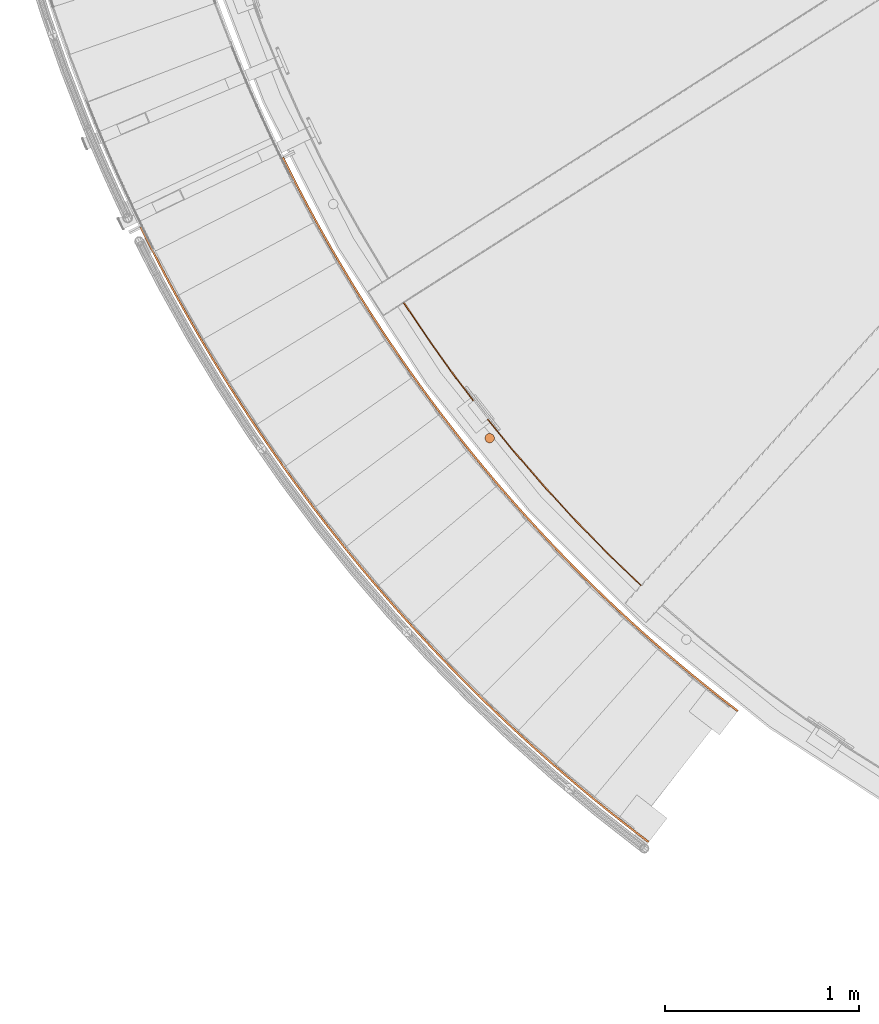
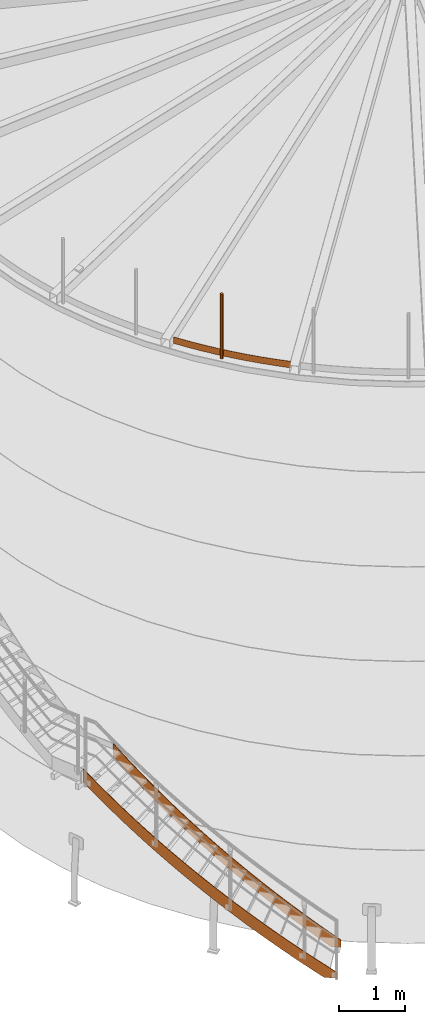
# One storey, part 4 of 126: 4 proxies.
"""IFC2X3 building model written with IfcOpenShell, lengths in millimetres."""

from ifc_helpers import new_model, si_unit, origin, origin_with_axes, place, context, project, spatial, faceted_brep, material, element, save


model = new_model("IFC2X3")

# Units and contexts
context_of_model_1 = context(None, 3, precision=0.1, world=origin())
context_of_model_2 = context(None, 3, precision=0.1, world=origin())
ifc_project = project(units=[si_unit("LENGTHUNIT", "METRE", prefix="MILLI"), si_unit("AREAUNIT", "SQUARE_METRE", prefix="CENTI"), si_unit("VOLUMEUNIT", "CUBIC_METRE", prefix="CENTI"), si_unit("MASSUNIT", "GRAM", prefix="KILO")], contexts=[context_of_model_1, context_of_model_2])

# Site, building, storey
site_placement = place(None, origin_with_axes())
site = spatial("IfcSite", under=ifc_project, at=site_placement, CompositionType="ELEMENT")
building_placement = place(site_placement, origin_with_axes())
building = spatial("IfcBuilding", under=site, at=building_placement, CompositionType="ELEMENT")
storey_placement = place(building_placement, origin_with_axes())
storey = spatial("IfcBuildingStorey", under=building, at=storey_placement, CompositionType="ELEMENT")

# Proxies
ifc_material_1 = material(Name="S235JRG2")
proxy_1_placement = place(storey_placement, origin_with_axes())
element("IfcBuildingElementProxy", 1, at=proxy_1_placement, inside=storey, material=ifc_material_1, context=context_of_model_2, shape_type="Brep", body=[
    faceted_brep([(2625.5117, 1016.7337, -0.15), (2625.5117, 1016.7337, 169.2948), (2697.6981, 961.7717, 108.7628), (2697.6981, 961.7717, -0.15), (2619.4117, 1008.8095, 169.3301), (2691.5898, 953.8538, 108.8737), (2619.4117, 1008.8095, -0.15), (2691.5898, 953.8538, -0.15), (2551.8092, 1074.0932, -0.15), (2551.8092, 1074.0932, 231.6041), (2545.6256, 1066.234, 231.6394), (2545.6256, 1066.234, -0.15), (2472.4517, 1124.4367, 53.6023), (2478.7181, 1132.2299, 53.4904), (2541.6434, 1082.179, -0.15), (2535.5735, 1074.2295, -0.15), (2478.7181, 1132.2299, 293.9133), (2472.4517, 1124.4367, 293.9486), (2399.8983, 1183.411, 115.9132), (2406.2469, 1191.1374, 115.798), (2406.2469, 1191.1374, 356.2226), (2399.8983, 1183.411, 356.2579), (2327.9735, 1243.1503, 178.2234), (2334.4035, 1250.8091, 178.1064), (2334.4035, 1250.8091, 418.5318), (2327.9735, 1243.1503, 418.5671), (2256.6853, 1303.648, 240.5331), (2263.1961, 1311.2382, 240.4151), (2263.1961, 1311.2382, 480.8411), (2256.6853, 1303.648, 480.8764), (2186.0418, 1364.8971, 302.8426), (2192.6326, 1372.418, 302.7241), (2192.6326, 1372.418, 543.1503), (2186.0418, 1364.8971, 543.1856), (2116.0508, 1426.891, 365.152), (2122.7209, 1434.3416, 365.0332), (2122.7209, 1434.3416, 605.4596), (2116.0508, 1426.891, 605.4949), (2046.7203, 1489.6225, 427.4613), (2053.4689, 1497.0021, 427.3424), (2053.4689, 1497.0021, 667.7688), (2046.7203, 1489.6225, 667.8041), (1978.058, 1553.0847, 489.7706), (1984.8844, 1560.3925, 489.6516), (1984.8844, 1560.3925, 730.0781), (1978.058, 1553.0847, 730.1134), (1910.0715, 1617.2705, 552.0799), (1916.9749, 1624.5056, 551.9608), (1916.9749, 1624.5056, 792.3873), (1910.0715, 1617.2705, 792.4226), (1842.7686, 1682.1727, 614.3892), (1849.7483, 1689.3342, 614.27), (1849.7483, 1689.3342, 854.6966), (1842.7686, 1682.1727, 854.7319), (1776.1568, 1747.7839, 676.6984), (1783.2119, 1754.8711, 676.5793), (1783.2119, 1754.8711, 917.0058), (1776.1568, 1747.7839, 917.0411), (1710.2435, 1814.0969, 739.0077), (1717.3733, 1821.109, 738.8885), (1717.3733, 1821.109, 979.315), (1710.2435, 1814.0969, 979.3504), (1645.0362, 1881.1041, 801.3169), (1652.2398, 1888.0403, 801.1978), (1652.2398, 1888.0403, 1041.6243), (1645.0362, 1881.1041, 1041.6596), (1580.5421, 1948.7981, 863.6262), (1587.8187, 1955.6577, 863.507), (1587.8187, 1955.6577, 1103.9335), (1580.5421, 1948.7981, 1103.9688), (1516.7685, 2017.1713, 925.9354), (1524.1174, 2023.9534, 925.8163), (1524.1174, 2023.9534, 1166.2428), (1516.7685, 2017.1713, 1166.2781), (1453.7225, 2086.2161, 988.2447), (1461.1428, 2092.92, 988.1255), (1461.1428, 2092.92, 1228.552), (1453.7225, 2086.2161, 1228.5873), (1391.4112, 2155.9245, 1050.5539), (1398.9021, 2162.5495, 1050.4347), (1398.9021, 2162.5495, 1290.8613), (1391.4112, 2155.9245, 1290.8966), (1329.8416, 2226.289, 1112.8631), (1337.4022, 2232.8342, 1112.744), (1337.4022, 2232.8342, 1353.1705), (1329.8416, 2226.289, 1353.2058), (1269.0206, 2297.3015, 1175.1724), (1276.6501, 2303.7663, 1175.0532), (1276.6501, 2303.7663, 1415.4798), (1269.0206, 2297.3015, 1415.5151), (1208.9551, 2368.9541, 1237.4816), (1216.6526, 2375.3377, 1237.3625), (1216.6526, 2375.3377, 1477.789), (1208.9551, 2368.9541, 1477.8243), (1149.6517, 2441.2388, 1299.7909), (1157.4163, 2447.5405, 1299.6717), (1157.4163, 2447.5405, 1540.0983), (1149.6517, 2441.2388, 1540.1336), (1091.117, 2514.1474, 1362.1001), (1098.948, 2520.3666, 1361.981), (1098.948, 2520.3666, 1602.4075), (1091.117, 2514.1474, 1602.4428), (1033.3578, 2587.6718, 1424.4094), (1041.2542, 2593.8077, 1424.2902), (1041.2542, 2593.8077, 1664.7168), (1033.3578, 2587.6718, 1664.7521), (976.3804, 2661.8037, 1486.7186), (984.3413, 2667.8557, 1486.5995), (984.3413, 2667.8557, 1727.026), (976.3804, 2661.8037, 1727.0613), (920.1912, 2736.5349, 1549.0279), (928.2158, 2742.5022, 1548.9087), (928.2158, 2742.5022, 1789.3353), (920.1912, 2736.5349, 1789.3706), (864.7966, 2811.8569, 1611.3371), (872.8839, 2817.7389, 1611.218), (872.8839, 2817.7389, 1851.6445), (864.7966, 2811.8569, 1851.6798), (810.2027, 2887.7613, 1673.6464), (818.3519, 2893.5573, 1673.5272), (818.3519, 2893.5573, 1913.9538), (810.2027, 2887.7613, 1913.9891), (756.4157, 2964.2396, 1735.9556), (764.6258, 2969.949, 1735.8365), (764.6258, 2969.949, 1976.263), (756.4157, 2964.2396, 1976.2983), (703.4416, 3041.2831, 1798.2649), (711.7117, 3046.9053, 1798.1457), (711.7117, 3046.9053, 2038.5723), (703.4416, 3041.2831, 2038.6076), (651.2863, 3118.8834, 1860.5741), (659.6155, 3124.4176, 1860.455), (659.6155, 3124.4176, 2100.8815), (651.2863, 3118.8834, 2100.9168), (599.9558, 3197.0316, 1922.8834), (608.3431, 3202.4773, 1922.7642), (608.3431, 3202.4773, 2163.1908), (599.9558, 3197.0316, 2163.2261), (549.4556, 3275.719, 1985.1926), (557.9001, 3281.0756, 1985.0735), (557.9001, 3281.0756, 2225.5), (549.4556, 3275.719, 2225.5353), (499.7916, 3354.9367, 2047.5019), (508.2924, 3360.2036, 2047.3827), (508.2924, 3360.2036, 2287.8092), (499.7916, 3354.9367, 2287.8446), (450.9693, 3434.676, 2109.8111), (459.5254, 3439.8526, 2109.692), (459.5254, 3439.8526, 2350.1185), (450.9693, 3434.676, 2350.1538), (402.9941, 3514.9278, 2172.1204), (411.6045, 3520.0135, 2172.0012), (411.6045, 3520.0135, 2412.4277), (402.9941, 3514.9278, 2412.463), (355.8715, 3595.6832, 2234.4296), (364.5353, 3600.6774, 2234.3105), (364.5353, 3600.6774, 2474.737), (355.8715, 3595.6832, 2474.7723), (309.6067, 3676.933, 2296.7389), (318.3229, 3681.8352, 2296.6197), (318.3229, 3681.8352, 2537.0462), (309.6067, 3676.933, 2537.0815), (264.2049, 3758.6682, 2359.0481), (272.9725, 3763.4778, 2358.9289), (272.9725, 3763.4778, 2599.3555), (264.2049, 3758.6682, 2599.3908), (219.6713, 3840.8797, 2421.3573), (228.4893, 3845.5961, 2421.2382), (228.4893, 3845.5961, 2661.6647), (219.6713, 3840.8797, 2661.7), (176.0107, 3923.5581, 2483.6666), (184.8781, 3928.1809, 2483.5474), (184.8781, 3928.1809, 2723.974), (176.0107, 3923.5581, 2724.0093), (133.2281, 4006.6942, 2545.9758), (142.144, 4011.2229, 2545.8567), (142.144, 4011.2229, 2786.2832), (133.2281, 4006.6942, 2786.3185), (91.3283, 4090.2788, 2608.2851), (100.2917, 4094.7128, 2608.1659), (100.2917, 4094.7128, 2848.5925), (91.3283, 4090.2788, 2848.6278), (76.422, 4120.8179, 2630.932), (85.3295, 4125.3664, 2630.9235), (85.3295, 4125.3664, 2871.35), (76.422, 4120.8179, 2871.2747)], [[[0, 1, 2, 3]], [[1, 4, 5, 2]], [[4, 6, 7, 5]], [[1, 0, 8, 9]], [[1, 9, 10, 4]], [[4, 10, 11, 6]], [[12, 13, 14, 15]], [[13, 16, 9, 8, 14]], [[9, 16, 17, 10]], [[17, 12, 15, 11, 10]], [[12, 18, 19, 13]], [[13, 19, 20, 16]], [[16, 20, 21, 17]], [[17, 21, 18, 12]], [[18, 22, 23, 19]], [[19, 23, 24, 20]], [[20, 24, 25, 21]], [[21, 25, 22, 18]], [[22, 26, 27, 23]], [[23, 27, 28, 24]], [[24, 28, 29, 25]], [[25, 29, 26, 22]], [[26, 30, 31, 27]], [[27, 31, 32, 28]], [[28, 32, 33, 29]], [[29, 33, 30, 26]], [[30, 34, 35, 31]], [[31, 35, 36, 32]], [[32, 36, 37, 33]], [[33, 37, 34, 30]], [[34, 38, 39, 35]], [[35, 39, 40, 36]], [[36, 40, 41, 37]], [[37, 41, 38, 34]], [[38, 42, 43, 39]], [[39, 43, 44, 40]], [[40, 44, 45, 41]], [[41, 45, 42, 38]], [[42, 46, 47, 43]], [[43, 47, 48, 44]], [[44, 48, 49, 45]], [[45, 49, 46, 42]], [[46, 50, 51, 47]], [[47, 51, 52, 48]], [[48, 52, 53, 49]], [[49, 53, 50, 46]], [[50, 54, 55, 51]], [[51, 55, 56, 52]], [[52, 56, 57, 53]], [[53, 57, 54, 50]], [[54, 58, 59, 55]], [[55, 59, 60, 56]], [[56, 60, 61, 57]], [[57, 61, 58, 54]], [[58, 62, 63, 59]], [[59, 63, 64, 60]], [[60, 64, 65, 61]], [[61, 65, 62, 58]], [[62, 66, 67, 63]], [[63, 67, 68, 64]], [[64, 68, 69, 65]], [[65, 69, 66, 62]], [[66, 70, 71, 67]], [[67, 71, 72, 68]], [[68, 72, 73, 69]], [[69, 73, 70, 66]], [[70, 74, 75, 71]], [[71, 75, 76, 72]], [[72, 76, 77, 73]], [[73, 77, 74, 70]], [[74, 78, 79, 75]], [[75, 79, 80, 76]], [[76, 80, 81, 77]], [[77, 81, 78, 74]], [[78, 82, 83, 79]], [[79, 83, 84, 80]], [[80, 84, 85, 81]], [[81, 85, 82, 78]], [[82, 86, 87, 83]], [[83, 87, 88, 84]], [[84, 88, 89, 85]], [[85, 89, 86, 82]], [[86, 90, 91, 87]], [[87, 91, 92, 88]], [[88, 92, 93, 89]], [[89, 93, 90, 86]], [[90, 94, 95, 91]], [[91, 95, 96, 92]], [[92, 96, 97, 93]], [[93, 97, 94, 90]], [[94, 98, 99, 95]], [[95, 99, 100, 96]], [[96, 100, 101, 97]], [[97, 101, 98, 94]], [[98, 102, 103, 99]], [[99, 103, 104, 100]], [[100, 104, 105, 101]], [[101, 105, 102, 98]], [[102, 106, 107, 103]], [[103, 107, 108, 104]], [[104, 108, 109, 105]], [[105, 109, 106, 102]], [[106, 110, 111, 107]], [[107, 111, 112, 108]], [[108, 112, 113, 109]], [[109, 113, 110, 106]], [[110, 114, 115, 111]], [[111, 115, 116, 112]], [[112, 116, 117, 113]], [[113, 117, 114, 110]], [[114, 118, 119, 115]], [[115, 119, 120, 116]], [[116, 120, 121, 117]], [[117, 121, 118, 114]], [[118, 122, 123, 119]], [[119, 123, 124, 120]], [[120, 124, 125, 121]], [[121, 125, 122, 118]], [[122, 126, 127, 123]], [[123, 127, 128, 124]], [[124, 128, 129, 125]], [[125, 129, 126, 122]], [[126, 130, 131, 127]], [[127, 131, 132, 128]], [[128, 132, 133, 129]], [[129, 133, 130, 126]], [[130, 134, 135, 131]], [[131, 135, 136, 132]], [[132, 136, 137, 133]], [[133, 137, 134, 130]], [[134, 138, 139, 135]], [[135, 139, 140, 136]], [[136, 140, 141, 137]], [[137, 141, 138, 134]], [[138, 142, 143, 139]], [[139, 143, 144, 140]], [[140, 144, 145, 141]], [[141, 145, 142, 138]], [[142, 146, 147, 143]], [[143, 147, 148, 144]], [[144, 148, 149, 145]], [[145, 149, 146, 142]], [[146, 150, 151, 147]], [[147, 151, 152, 148]], [[148, 152, 153, 149]], [[149, 153, 150, 146]], [[150, 154, 155, 151]], [[151, 155, 156, 152]], [[152, 156, 157, 153]], [[153, 157, 154, 150]], [[154, 158, 159, 155]], [[155, 159, 160, 156]], [[156, 160, 161, 157]], [[157, 161, 158, 154]], [[158, 162, 163, 159]], [[159, 163, 164, 160]], [[160, 164, 165, 161]], [[161, 165, 162, 158]], [[162, 166, 167, 163]], [[163, 167, 168, 164]], [[164, 168, 169, 165]], [[165, 169, 166, 162]], [[166, 170, 171, 167]], [[167, 171, 172, 168]], [[168, 172, 173, 169]], [[169, 173, 170, 166]], [[170, 174, 175, 171]], [[171, 175, 176, 172]], [[172, 176, 177, 173]], [[173, 177, 174, 170]], [[174, 178, 179, 175]], [[175, 179, 180, 176]], [[176, 180, 181, 177]], [[177, 181, 178, 174]], [[178, 182, 183, 179]], [[179, 183, 184, 180]], [[180, 184, 185, 181]], [[178, 181, 185, 182]], [[182, 185, 184, 183]], [[15, 14, 8, 0, 3, 7, 6, 11]], [[2, 5, 7, 3]]]),
])
proxy_2_placement = place(storey_placement, origin_with_axes())
element("IfcBuildingElementProxy", 2, at=proxy_2_placement, inside=storey, material=ifc_material_1, context=context_of_model_2, shape_type="Brep", body=[
    faceted_brep([(3122.0424, 1661.7556, -0.15), (3122.0424, 1661.7556, 169.293), (3156.2567, 1635.7052, 137.6852), (3156.2567, 1635.7052, -0.15), (3115.9424, 1653.8314, 169.3319), (3150.1894, 1627.7561, 137.7334), (3115.9424, 1653.8314, -0.15), (3150.1894, 1627.7561, -0.15), (3055.1426, 1713.8208, -0.15), (3055.1426, 1713.8208, 231.6023), (3048.9591, 1705.9616, 231.6412), (3048.9591, 1705.9616, -0.15), (2982.5316, 1758.7982, 45.839), (2988.798, 1766.5915, 45.7041), (3037.6253, 1727.7542, -0.15), (3031.5567, 1719.8035, -0.15), (2988.798, 1766.5915, 293.9115), (2982.5316, 1758.7982, 293.9504), (2916.6673, 1812.3353, 108.1509), (2923.0159, 1820.0618, 108.0107), (2923.0159, 1820.0618, 356.2208), (2916.6673, 1812.3353, 356.2597), (2851.3736, 1866.5669, 170.4616), (2857.8037, 1874.2257, 170.3184), (2857.8037, 1874.2257, 418.53), (2851.3736, 1866.5669, 418.5689), (2786.6579, 1921.4869, 232.7718), (2793.1688, 1929.0772, 232.6268), (2793.1688, 1929.0772, 480.8393), (2786.6579, 1921.4869, 480.8782), (2722.5275, 1977.0891, 295.0815), (2729.1183, 1984.61, 294.9355), (2729.1183, 1984.61, 543.1485), (2722.5275, 1977.0891, 543.1874), (2658.9894, 2033.3674, 357.3911), (2665.6595, 2040.8181, 357.2444), (2665.6595, 2040.8181, 605.4578), (2658.9894, 2033.3674, 605.4967), (2596.0509, 2090.3153, 419.7005), (2602.7995, 2097.695, 419.5535), (2602.7995, 2097.695, 667.767), (2596.0509, 2090.3153, 667.8059), (2533.719, 2147.9266, 482.0099), (2540.5454, 2155.2343, 481.8627), (2540.5454, 2155.2343, 730.0763), (2533.719, 2147.9266, 730.1152), (2472.0007, 2206.1947, 544.3192), (2478.9041, 2213.4297, 544.1719), (2478.9041, 2213.4297, 792.3855), (2472.0007, 2206.1947, 792.4244), (2410.9028, 2265.1131, 606.6284), (2417.8825, 2272.2747, 606.4811), (2417.8825, 2272.2747, 854.6948), (2410.9028, 2265.1131, 854.7336), (2350.4324, 2324.6753, 668.9377), (2357.4874, 2331.7625, 668.7903), (2357.4874, 2331.7625, 917.004), (2350.4324, 2324.6753, 917.0429), (2290.596, 2384.8744, 731.247), (2297.7258, 2391.8865, 731.0995), (2297.7258, 2391.8865, 979.3132), (2290.596, 2384.8744, 979.3521), (2231.4005, 2445.7039, 793.5562), (2238.6041, 2452.6401, 793.4088), (2238.6041, 2452.6401, 1041.6225), (2231.4005, 2445.7039, 1041.6614), (2172.8526, 2507.1567, 855.8655), (2180.1292, 2514.0163, 855.718), (2180.1292, 2514.0163, 1103.9317), (2172.8526, 2507.1567, 1103.9706), (2114.9586, 2569.2262, 918.1747), (2122.3075, 2576.0083, 918.0273), (2122.3075, 2576.0083, 1166.241), (2114.9586, 2569.2262, 1166.2799), (2057.7252, 2631.9053, 980.484), (2065.1455, 2638.6092, 980.3365), (2065.1455, 2638.6092, 1228.5502), (2057.7252, 2631.9053, 1228.5891), (2001.1588, 2695.1869, 1042.7932), (2008.6497, 2701.8118, 1042.6458), (2008.6497, 2701.8118, 1290.8595), (2001.1588, 2695.1869, 1290.8984), (1945.2657, 2759.064, 1105.1025), (1952.8263, 2765.6093, 1104.955), (1952.8263, 2765.6093, 1353.1687), (1945.2657, 2759.064, 1353.2076), (1890.0522, 2823.5294, 1167.4117), (1897.6817, 2829.9943, 1167.2642), (1897.6817, 2829.9943, 1415.478), (1890.0522, 2823.5294, 1415.5169), (1835.5244, 2888.576, 1229.721), (1843.2219, 2894.9596, 1229.5735), (1843.2219, 2894.9596, 1477.7872), (1835.5244, 2888.576, 1477.8261), (1781.6885, 2954.1963, 1292.0302), (1789.4532, 2960.498, 1291.8827), (1789.4532, 2960.498, 1540.0965), (1781.6885, 2954.1963, 1540.1354), (1728.5506, 3020.383, 1354.3395), (1736.3816, 3026.6022, 1354.192), (1736.3816, 3026.6022, 1602.4057), (1728.5506, 3020.383, 1602.4446), (1676.1165, 3087.1287, 1416.6487), (1684.0129, 3093.2646, 1416.5012), (1684.0129, 3093.2646, 1664.715), (1676.1165, 3087.1287, 1664.7539), (1624.3922, 3154.426, 1478.958), (1632.3531, 3160.4779, 1478.8105), (1632.3531, 3160.4779, 1727.0242), (1624.3922, 3154.426, 1727.0631), (1573.3835, 3222.2672, 1541.2672), (1581.408, 3228.2345, 1541.1197), (1581.408, 3228.2345, 1789.3335), (1573.3835, 3222.2672, 1789.3724), (1523.096, 3290.6448, 1603.5765), (1531.1833, 3296.5268, 1603.429), (1531.1833, 3296.5268, 1851.6427), (1523.096, 3290.6448, 1851.6816), (1473.5355, 3359.5511, 1665.8857), (1481.6846, 3365.3472, 1665.7382), (1481.6846, 3365.3472, 1913.952), (1473.5355, 3359.5511, 1913.9909), (1424.7074, 3428.9784, 1728.195), (1432.9175, 3434.6878, 1728.0475), (1432.9175, 3434.6878, 1976.2612), (1424.7074, 3428.9784, 1976.3001), (1376.6173, 3498.9189, 1790.5042), (1384.8874, 3504.541, 1790.3567), (1384.8874, 3504.541, 2038.5705), (1376.6173, 3498.9189, 2038.6094), (1329.2705, 3569.3647, 1852.8134), (1337.5997, 3574.8989, 1852.666), (1337.5997, 3574.8989, 2100.8797), (1329.2705, 3569.3647, 2100.9186), (1282.6725, 3640.3079, 1915.1227), (1291.0598, 3645.7536, 1914.9752), (1291.0598, 3645.7536, 2163.189), (1282.6725, 3640.3079, 2163.2279), (1236.8283, 3711.7406, 1977.4319), (1245.2728, 3717.0972, 1977.2845), (1245.2728, 3717.0972, 2225.4982), (1236.8283, 3711.7406, 2225.5371), (1191.7431, 3783.6548, 2039.7412), (1200.2438, 3788.9217, 2039.5937), (1200.2438, 3788.9217, 2287.8075), (1191.7431, 3783.6548, 2287.8463), (1147.422, 3856.0424, 2102.0504), (1155.978, 3861.219, 2101.903), (1155.978, 3861.219, 2350.1167), (1147.422, 3856.0424, 2350.1556), (1103.8699, 3928.8953, 2164.3597), (1112.4803, 3933.981, 2164.2122), (1112.4803, 3933.981, 2412.4259), (1103.8699, 3928.8953, 2412.4648), (1061.0918, 4002.2054, 2226.6689), (1069.7556, 4007.1996, 2226.5215), (1069.7556, 4007.1996, 2474.7352), (1061.0918, 4002.2054, 2474.7741), (1019.0925, 4075.9643, 2288.9782), (1027.8086, 4080.8665, 2288.8307), (1027.8086, 4080.8665, 2537.0444), (1019.0925, 4075.9643, 2537.0833), (977.8766, 4150.1638, 2351.2874), (986.6441, 4154.9734, 2351.14), (986.6441, 4154.9734, 2599.3537), (977.8766, 4150.1638, 2599.3926), (937.4487, 4224.7957, 2413.5967), (946.2667, 4229.5122, 2413.4492), (946.2667, 4229.5122, 2661.6629), (937.4487, 4224.7957, 2661.7018), (897.8135, 4299.8515, 2475.9059), (906.6809, 4304.4743, 2475.7584), (906.6809, 4304.4743, 2723.9722), (897.8135, 4299.8515, 2724.0111), (858.9753, 4375.3228, 2538.2152), (867.8912, 4379.8515, 2538.0677), (867.8912, 4379.8515, 2786.2814), (858.9753, 4375.3228, 2786.3203), (820.9385, 4451.2012, 2600.5244), (829.9018, 4455.6352, 2600.3769), (829.9018, 4455.6352, 2848.5907), (820.9385, 4451.2012, 2848.6296), (808.4871, 4476.7108, 2621.3627), (817.3946, 4481.2592, 2621.3349), (817.3946, 4481.2592, 2869.5486), (808.4871, 4476.7108, 2869.4679)], [[[0, 1, 2, 3]], [[1, 4, 5, 2]], [[4, 6, 7, 5]], [[1, 0, 8, 9]], [[1, 9, 10, 4]], [[4, 10, 11, 6]], [[12, 13, 14, 15]], [[16, 9, 8, 14, 13]], [[9, 16, 17, 10]], [[17, 12, 15, 11, 10]], [[12, 18, 19, 13]], [[13, 19, 20, 16]], [[16, 20, 21, 17]], [[17, 21, 18, 12]], [[18, 22, 23, 19]], [[19, 23, 24, 20]], [[20, 24, 25, 21]], [[21, 25, 22, 18]], [[22, 26, 27, 23]], [[23, 27, 28, 24]], [[24, 28, 29, 25]], [[25, 29, 26, 22]], [[26, 30, 31, 27]], [[27, 31, 32, 28]], [[28, 32, 33, 29]], [[29, 33, 30, 26]], [[30, 34, 35, 31]], [[31, 35, 36, 32]], [[32, 36, 37, 33]], [[33, 37, 34, 30]], [[34, 38, 39, 35]], [[35, 39, 40, 36]], [[36, 40, 41, 37]], [[37, 41, 38, 34]], [[38, 42, 43, 39]], [[39, 43, 44, 40]], [[40, 44, 45, 41]], [[41, 45, 42, 38]], [[42, 46, 47, 43]], [[43, 47, 48, 44]], [[44, 48, 49, 45]], [[45, 49, 46, 42]], [[46, 50, 51, 47]], [[47, 51, 52, 48]], [[48, 52, 53, 49]], [[49, 53, 50, 46]], [[50, 54, 55, 51]], [[51, 55, 56, 52]], [[52, 56, 57, 53]], [[53, 57, 54, 50]], [[54, 58, 59, 55]], [[55, 59, 60, 56]], [[56, 60, 61, 57]], [[57, 61, 58, 54]], [[58, 62, 63, 59]], [[59, 63, 64, 60]], [[60, 64, 65, 61]], [[61, 65, 62, 58]], [[62, 66, 67, 63]], [[63, 67, 68, 64]], [[64, 68, 69, 65]], [[65, 69, 66, 62]], [[66, 70, 71, 67]], [[67, 71, 72, 68]], [[68, 72, 73, 69]], [[69, 73, 70, 66]], [[70, 74, 75, 71]], [[71, 75, 76, 72]], [[72, 76, 77, 73]], [[73, 77, 74, 70]], [[74, 78, 79, 75]], [[75, 79, 80, 76]], [[76, 80, 81, 77]], [[77, 81, 78, 74]], [[78, 82, 83, 79]], [[79, 83, 84, 80]], [[80, 84, 85, 81]], [[81, 85, 82, 78]], [[82, 86, 87, 83]], [[83, 87, 88, 84]], [[84, 88, 89, 85]], [[85, 89, 86, 82]], [[86, 90, 91, 87]], [[87, 91, 92, 88]], [[88, 92, 93, 89]], [[89, 93, 90, 86]], [[90, 94, 95, 91]], [[91, 95, 96, 92]], [[92, 96, 97, 93]], [[93, 97, 94, 90]], [[94, 98, 99, 95]], [[95, 99, 100, 96]], [[96, 100, 101, 97]], [[97, 101, 98, 94]], [[98, 102, 103, 99]], [[99, 103, 104, 100]], [[100, 104, 105, 101]], [[101, 105, 102, 98]], [[102, 106, 107, 103]], [[103, 107, 108, 104]], [[104, 108, 109, 105]], [[105, 109, 106, 102]], [[106, 110, 111, 107]], [[107, 111, 112, 108]], [[108, 112, 113, 109]], [[109, 113, 110, 106]], [[110, 114, 115, 111]], [[111, 115, 116, 112]], [[112, 116, 117, 113]], [[113, 117, 114, 110]], [[114, 118, 119, 115]], [[115, 119, 120, 116]], [[116, 120, 121, 117]], [[117, 121, 118, 114]], [[118, 122, 123, 119]], [[119, 123, 124, 120]], [[120, 124, 125, 121]], [[121, 125, 122, 118]], [[122, 126, 127, 123]], [[123, 127, 128, 124]], [[124, 128, 129, 125]], [[125, 129, 126, 122]], [[126, 130, 131, 127]], [[127, 131, 132, 128]], [[128, 132, 133, 129]], [[129, 133, 130, 126]], [[130, 134, 135, 131]], [[131, 135, 136, 132]], [[132, 136, 137, 133]], [[133, 137, 134, 130]], [[134, 138, 139, 135]], [[135, 139, 140, 136]], [[136, 140, 141, 137]], [[137, 141, 138, 134]], [[138, 142, 143, 139]], [[139, 143, 144, 140]], [[140, 144, 145, 141]], [[141, 145, 142, 138]], [[142, 146, 147, 143]], [[143, 147, 148, 144]], [[144, 148, 149, 145]], [[145, 149, 146, 142]], [[146, 150, 151, 147]], [[147, 151, 152, 148]], [[148, 152, 153, 149]], [[149, 153, 150, 146]], [[150, 154, 155, 151]], [[151, 155, 156, 152]], [[152, 156, 157, 153]], [[153, 157, 154, 150]], [[154, 158, 159, 155]], [[155, 159, 160, 156]], [[156, 160, 161, 157]], [[157, 161, 158, 154]], [[158, 162, 163, 159]], [[159, 163, 164, 160]], [[160, 164, 165, 161]], [[161, 165, 162, 158]], [[162, 166, 167, 163]], [[163, 167, 168, 164]], [[164, 168, 169, 165]], [[165, 169, 166, 162]], [[166, 170, 171, 167]], [[167, 171, 172, 168]], [[168, 172, 173, 169]], [[169, 173, 170, 166]], [[170, 174, 175, 171]], [[171, 175, 176, 172]], [[172, 176, 177, 173]], [[173, 177, 174, 170]], [[174, 178, 179, 175]], [[175, 179, 180, 176]], [[176, 180, 181, 177]], [[177, 181, 178, 174]], [[178, 182, 183, 179]], [[179, 183, 184, 180]], [[180, 184, 185, 181]], [[178, 181, 185, 182]], [[182, 185, 184, 183]], [[7, 6, 11, 15, 14, 8, 0, 3]], [[2, 5, 7, 3]]]),
])
ifc_material_2 = material(Name="STAHL")
proxy_3_placement = place(storey_placement, origin_with_axes())
element("IfcBuildingElementProxy", 3, at=proxy_3_placement, inside=storey, material=ifc_material_2, Name="profile", context=context_of_model_2, shape_type="Brep", body=[
    faceted_brep([(1879.1, 3059.6, 11706.0), (1879.1, 3059.6, 10506.0), (1873.2, 3059.5, 10506.0), (1873.2, 3059.5, 11706.0), (1867.6, 3058.0, 10506.0), (1867.6, 3058.0, 11706.0), (1862.5, 3055.2, 10506.0), (1862.5, 3055.2, 11706.0), (1858.2, 3051.2, 10506.0), (1858.2, 3051.2, 11706.0), (1855.0, 3046.3, 10506.0), (1855.0, 3046.3, 11706.0), (1853.1, 3040.9, 10506.0), (1853.1, 3040.9, 11706.0), (1852.5, 3035.1, 10506.0), (1852.5, 3035.1, 11706.0), (1853.3, 3029.3, 10506.0), (1853.3, 3029.3, 11706.0), (1855.5, 3023.9, 10506.0), (1855.5, 3023.9, 11706.0), (1858.9, 3019.2, 10506.0), (1858.9, 3019.2, 11706.0), (1863.3, 3015.4, 10506.0), (1863.3, 3015.4, 11706.0), (1868.5, 3012.8, 10506.0), (1868.5, 3012.8, 11706.0), (1874.2, 3011.5, 11706.0), (1874.2, 3011.5, 10506.0), (1880.0, 3011.7, 10506.0), (1880.0, 3011.7, 11706.0), (1885.7, 3013.2, 11706.0), (1885.7, 3013.2, 10506.0), (1890.8, 3016.0, 11706.0), (1890.8, 3016.0, 10506.0), (1895.0, 3019.9, 11706.0), (1895.0, 3019.9, 10506.0), (1898.3, 3024.8, 11706.0), (1898.3, 3024.8, 10506.0), (1900.2, 3030.3, 11706.0), (1900.2, 3030.3, 10506.0), (1900.8, 3036.1, 11706.0), (1900.8, 3036.1, 10506.0), (1900.0, 3041.8, 11706.0), (1900.0, 3041.8, 10506.0), (1897.8, 3047.2, 11706.0), (1897.8, 3047.2, 10506.0), (1894.4, 3051.9, 11706.0), (1894.4, 3051.9, 10506.0), (1889.9, 3055.7, 11706.0), (1889.9, 3055.7, 10506.0), (1884.7, 3058.3, 11706.0), (1884.7, 3058.3, 10506.0)], [[[0, 1, 2, 3]], [[3, 2, 4, 5]], [[5, 4, 6, 7]], [[7, 6, 8, 9]], [[9, 8, 10, 11]], [[11, 10, 12, 13]], [[13, 12, 14, 15]], [[15, 14, 16, 17]], [[17, 16, 18, 19]], [[19, 18, 20, 21]], [[21, 20, 22, 23]], [[23, 22, 24, 25]], [[26, 25, 24, 27]], [[26, 27, 28, 29]], [[30, 29, 28, 31]], [[32, 30, 31, 33]], [[34, 32, 33, 35]], [[36, 34, 35, 37]], [[38, 36, 37, 39]], [[40, 38, 39, 41]], [[42, 40, 41, 43]], [[44, 42, 43, 45]], [[46, 44, 45, 47]], [[48, 46, 47, 49]], [[50, 48, 49, 51]], [[0, 50, 51, 1]], [[26, 29, 30, 32, 34, 36, 38, 40, 42, 44, 46, 48, 50, 0, 3, 5, 7, 9, 11, 13, 15, 17, 19, 21, 23, 25]], [[27, 24, 22, 20, 18, 16, 14, 12, 10, 8, 6, 4, 2, 1, 51, 49, 47, 45, 43, 41, 39, 37, 35, 33, 31, 28]]]),
])
proxy_4_placement = place(storey_placement, origin_with_axes())
element("IfcBuildingElementProxy", 4, at=proxy_4_placement, inside=storey, material=ifc_material_2, Name="profile", context=context_of_model_2, shape_type="Brep", body=[
    faceted_brep([(2653.0, 2276.1, 10516.0), (2653.0, 2276.1, 10636.0), (2481.7, 2441.2, 10636.0), (2315.4, 2611.3, 10636.0), (2154.3, 2786.5, 10636.0), (1998.7, 2966.4, 10636.0), (1848.6, 3151.0, 10636.0), (1704.1, 3340.0, 10636.0), (1565.5, 3533.4, 10636.0), (1432.7, 3730.8, 10636.0), (1432.7, 3730.8, 10516.0), (1565.5, 3533.4, 10516.0), (1704.1, 3340.0, 10516.0), (1848.6, 3151.0, 10516.0), (1998.7, 2966.4, 10516.0), (2154.3, 2786.5, 10516.0), (2315.4, 2611.3, 10516.0), (2481.7, 2441.2, 10516.0), (2656.5, 2279.8, 10636.0), (2485.2, 2444.7, 10636.0), (2319.0, 2614.8, 10636.0), (2158.1, 2789.8, 10636.0), (2002.5, 2969.6, 10636.0), (1852.5, 3154.1, 10636.0), (1708.1, 3343.0, 10636.0), (1569.6, 3536.2, 10636.0), (1436.9, 3733.5, 10636.0), (2656.5, 2279.8, 10516.0), (2485.2, 2444.7, 10516.0), (2319.0, 2614.8, 10516.0), (2158.1, 2789.8, 10516.0), (2002.5, 2969.6, 10516.0), (1852.5, 3154.1, 10516.0), (1708.1, 3343.0, 10516.0), (1569.6, 3536.2, 10516.0), (1436.9, 3733.5, 10516.0)], [[[0, 1, 2, 3, 4, 5, 6, 7, 8, 9, 10, 11, 12, 13, 14, 15, 16, 17]], [[1, 18, 19, 20, 21, 22, 23, 24, 25, 26, 9, 8, 7, 6, 5, 4, 3, 2]], [[18, 27, 28, 29, 30, 31, 32, 33, 34, 35, 26, 25, 24, 23, 22, 21, 20, 19]], [[0, 17, 16, 15, 14, 13, 12, 11, 10, 35, 34, 33, 32, 31, 30, 29, 28, 27]], [[18, 1, 0, 27]], [[26, 35, 10, 9]]]),
])

save(model, "model.ifc")
